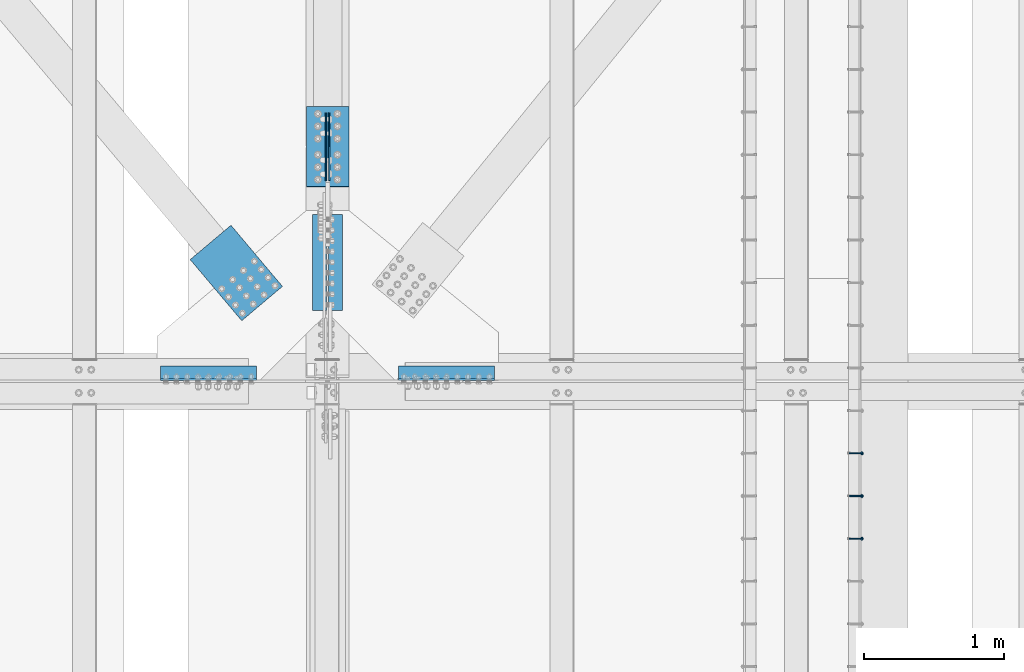
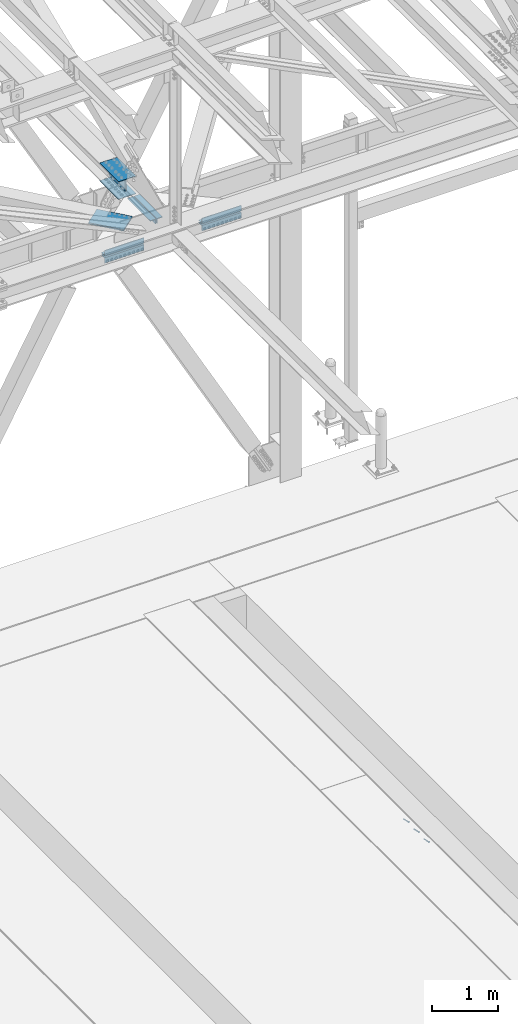
# One storey, part 2492 of 3843: 11 beams, 3 members, 5 elements without a shape of their own.
"""IFC2X3 building model written with IfcOpenShell, lengths in millimetres."""

import ifcopenshell
import ifcopenshell.guid

model = None  # the IFC model being written
_history = None  # IfcOwnerHistory: only IFC2X3 demands one
_inside = {}  # id of a spatial element -> (the spatial element, [elements in it])
_under = {}  # id of a project, library or spatial element -> (it, [spatial elements below it])
_declared = {}  # id of a project -> (the project, [libraries it declares])
_typed = {}  # id of a type object -> (the type object, [elements of that type])
_made_of = {}  # id of a material, layer set ... -> (it, [elements and type objects made of it])


def new_model(schema):
    """Start an empty IFC model of exactly this schema.

    Asked for "IFC4X3", IfcOpenShell would pick the latest addendum, in which some entities
    have other attributes; the version numbers below select the first issue.
    IFC2X3 requires an IfcOwnerHistory on every rooted entity: one is made here for all.
    """
    global model, _history
    if schema == "IFC4X3":
        model = ifcopenshell.file(schema_version=(4, 3, 0, 0))
    else:
        model = ifcopenshell.file(schema=schema)
    _inside.clear()
    _under.clear()
    _declared.clear()
    _typed.clear()
    _made_of.clear()
    _history = None
    if model.schema == "IFC2X3":
        org = make("IfcOrganization", Name="unknown")
        user = make(
            "IfcPersonAndOrganization",
            ThePerson=make("IfcPerson", FamilyName="unknown"),
            TheOrganization=org,
        )
        app = make(
            "IfcApplication",
            ApplicationDeveloper=org,
            Version="unknown",
            ApplicationFullName="unknown",
            ApplicationIdentifier="unknown",
        )
        _history = make(
            "IfcOwnerHistory",
            OwningUser=user,
            OwningApplication=app,
            ChangeAction="ADDED",
            CreationDate=0,
        )
    return model


def make(cls, **values):
    """One entity of the class cls with the attributes given. An attribute that is None is left unset."""
    return model.create_entity(
        cls, **{name: value for name, value in values.items() if value is not None}
    )


def rooted(cls, **values):
    """An entity with a GlobalId (a new one), such as an element, a storey or a relation."""
    return make(cls, GlobalId=ifcopenshell.guid.new(), OwnerHistory=_history, **values)


def si_unit(unit_type, name, prefix=None):
    """IfcSIUnit, for example si_unit("LENGTHUNIT", "METRE", prefix="MILLI")."""
    return make("IfcSIUnit", UnitType=unit_type, Prefix=prefix, Name=name)


def assignment(units):
    """IfcUnitAssignment: the units of a project."""
    return None if units is None else make("IfcUnitAssignment", Units=units)


def point(xyz):
    """IfcCartesianPoint."""
    return None if xyz is None else make("IfcCartesianPoint", Coordinates=xyz)


def direction(xyz):
    """IfcDirection."""
    return None if xyz is None else make("IfcDirection", DirectionRatios=xyz)


def frame(location, z_axis=None, x_axis=None):
    """IfcAxis2Placement3D, a coordinate frame: its origin and axes. An axis left out is left unset."""
    return make(
        "IfcAxis2Placement3D",
        Location=point(location),
        Axis=direction(z_axis),
        RefDirection=direction(x_axis),
    )


def origin_with_axes():
    """The frame at (0, 0, 0) with the z axis (0, 0, 1) and the x axis (1, 0, 0) written out."""
    return frame((0.0, 0.0, 0.0), z_axis=(0.0, 0.0, 1.0), x_axis=(1.0, 0.0, 0.0))


def place(relative_to, where):
    """IfcLocalPlacement: puts the frame where relative to a parent placement (None: the world)."""
    return make(
        "IfcLocalPlacement", PlacementRelTo=relative_to, RelativePlacement=where
    )


def context(
    kind, dimensions, precision=None, world=None, true_north=None, identifier=None
):
    """IfcGeometricRepresentationContext, for example the 3D "Model" context."""
    return make(
        "IfcGeometricRepresentationContext",
        ContextIdentifier=identifier,
        ContextType=kind,
        CoordinateSpaceDimension=dimensions,
        Precision=precision,
        WorldCoordinateSystem=world,
        TrueNorth=true_north,
    )


def subcontext(parent, identifier, kind, view, scale=None):
    """IfcGeometricRepresentationSubContext, for example "Body" below "Model"."""
    return make(
        "IfcGeometricRepresentationSubContext",
        ContextIdentifier=identifier,
        ContextType=kind,
        ParentContext=parent,
        TargetScale=scale,
        TargetView=view,
    )


def project(units=None, contexts=None):
    """IfcProject with its units and contexts."""
    return rooted(
        "IfcProject",
        Name="project",
        RepresentationContexts=contexts,
        UnitsInContext=assignment(units),
    )


def spatial(cls, under=None, at=None, **own):
    """A site, building, storey or space (cls), placed at a placement, below another one or the project."""
    s = rooted(cls, ObjectPlacement=at, **own)
    if under is not None:
        _under.setdefault(under.id(), (under, []))[1].append(s)
    return s


def faces_of(points, faces, orient=None, outer=None):
    """IfcFace entities. A face is a list of loops; a loop is a list of indices into points, from 0.

    orient and outer hold one flag for each loop. By default every Orientation is true, the
    first loop of a face is its IfcFaceOuterBound and the others are IfcFaceBound.
    """
    made = []
    for i, loops in enumerate(faces):
        bounds = []
        for j, loop in enumerate(loops):
            is_outer = j == 0 if outer is None else outer[i][j]
            bounds.append(
                make(
                    "IfcFaceOuterBound" if is_outer else "IfcFaceBound",
                    Bound=make("IfcPolyLoop", Polygon=[points[k] for k in loop]),
                    Orientation=True if orient is None else orient[i][j],
                )
            )
        made.append(make("IfcFace", Bounds=bounds))
    return made


def faceted_brep(points, faces, orient=None, outer=None, voids=None):
    """IfcFacetedBrep: a solid bounded by flat faces; with voids (closed shells), ...WithVoids."""
    shared = [point(p) for p in points]
    hull = make("IfcClosedShell", CfsFaces=faces_of(shared, faces, orient, outer))
    if voids is None:
        return make("IfcFacetedBrep", Outer=hull)
    return make(
        "IfcFacetedBrepWithVoids",
        Outer=hull,
        Voids=[
            make(cls, CfsFaces=faces_of(shared, fs, o, b)) for cls, fs, o, b in voids
        ],
    )


def shape(context_of_items, identifier, shape_type, items):
    """IfcShapeRepresentation: the items that make up one representation, for example the "Body"."""
    return make(
        "IfcShapeRepresentation",
        ContextOfItems=context_of_items,
        RepresentationIdentifier=identifier,
        RepresentationType=shape_type,
        Items=items,
    )


def material(Name=None, Category=None):
    """IfcMaterial."""
    return make("IfcMaterial", Name=Name, Category=Category)


def made_of(thing, what):
    """Note that an element or type object is made of a material, layer set ...; save() writes the relation."""
    if what is not None:
        _made_of.setdefault(what.id(), (what, []))[1].append(thing)
    return thing


def type_object(cls, material=None, **own):
    """A type object (cls), such as IfcWallType, which elements share."""
    return made_of(rooted(cls, **own), material)


def element(
    cls,
    number,
    at=None,
    inside=None,
    cuts=None,
    type_object=None,
    material=None,
    context=None,
    identifier="Body",
    shape_type=None,
    held_by="IfcProductDefinitionShape",
    body=None,
    shapes=None,
    **own,
):
    """One element of the class cls, such as IfcWall. Its Tag is "e" and its number.

    at: its placement. inside: the storey or other place that contains it. cuts: it is an
    opening in that element (IfcRelVoidsElement). A single representation is given by context,
    identifier, shape_type and body (its items); several are given by shapes. held_by: the class
    of the entity that holds the representations. save() writes the other relations.
    """
    e = rooted(cls, Tag="e%d" % number, ObjectPlacement=at, **own)
    if body is not None:
        shapes = [shape(context, identifier, shape_type, body)]
    if shapes is not None:
        e.Representation = make(held_by, Representations=shapes)
    if inside is not None:
        _inside.setdefault(inside.id(), (inside, []))[1].append(e)
    if cuts is not None:
        rooted(
            "IfcRelVoidsElement", RelatingBuildingElement=cuts, RelatedOpeningElement=e
        )
    if type_object is not None:
        _typed.setdefault(type_object.id(), (type_object, []))[1].append(e)
    return made_of(e, material)


def aggregate(whole, parts):
    """IfcRelAggregates: a whole, such as a stair, and the parts it consists of."""
    return rooted("IfcRelAggregates", RelatingObject=whole, RelatedObjects=parts)


def save(model, path):
    """Write the relations noted so far, then the file.

    IfcRelAggregates (storeys below a building ...), IfcRelContainedInSpatialStructure (elements
    in a storey), IfcRelDefinesByType, IfcRelAssociatesMaterial and IfcRelDeclares: one each for
    every whole, place, type object, material and project.
    """
    for whole, parts in _under.values():
        aggregate(whole, parts)
    for where, things in _inside.values():
        rooted(
            "IfcRelContainedInSpatialStructure",
            RelatedElements=things,
            RelatingStructure=where,
        )
    for kind, things in _typed.values():
        rooted("IfcRelDefinesByType", RelatedObjects=things, RelatingType=kind)
    for what, things in _made_of.values():
        rooted("IfcRelAssociatesMaterial", RelatedObjects=things, RelatingMaterial=what)
    for by, libraries in _declared.values():
        rooted("IfcRelDeclares", RelatingContext=by, RelatedDefinitions=libraries)
    model.write(path)


model = new_model("IFC2X3")

# Units and contexts
model_context = context("Model", 3, precision=1e-05, world=origin_with_axes())
body_context = subcontext(model_context, "Body", "Model", "MODEL_VIEW")
ifc_project = project(units=[si_unit("LENGTHUNIT", "METRE", prefix="MILLI"), si_unit("AREAUNIT", "SQUARE_METRE"), si_unit("VOLUMEUNIT", "CUBIC_METRE"), si_unit("MASSUNIT", "GRAM", prefix="KILO"), si_unit("TIMEUNIT", "SECOND"), si_unit("PLANEANGLEUNIT", "RADIAN"), si_unit("SOLIDANGLEUNIT", "STERADIAN"), si_unit("THERMODYNAMICTEMPERATUREUNIT", "DEGREE_CELSIUS"), si_unit("LUMINOUSINTENSITYUNIT", "LUMEN")], contexts=[model_context])

# Site, building, storey
site_placement = place(None, origin_with_axes())
site = spatial("IfcSite", under=ifc_project, at=site_placement, CompositionType="ELEMENT")
building_placement = place(site_placement, origin_with_axes())
building = spatial("IfcBuilding", under=site, at=building_placement, Name="Undefined", CompositionType="ELEMENT")
storey_placement = place(building_placement, origin_with_axes())
storey = spatial("IfcBuildingStorey", under=building, at=storey_placement, Name="Undefined", CompositionType="ELEMENT", Elevation=0.0)

# Assembly, members
assembly_1_placement = place(storey_placement, origin_with_axes())
assembly_1 = element("IfcElementAssembly", 1, at=assembly_1_placement, inside=storey, Name="EMBED_ANGLE", AssemblyPlace="NOTDEFINED", PredefinedType="RIGID_FRAME")
ifc_material_1 = material(Name="STEEL/A108")
member_type = type_object("IfcMemberType", PredefinedType="NOTDEFINED")
member_1_placement = place(assembly_1_placement, frame((59660.5996396484, 82861.0223186035, 30446.6625), z_axis=(0.0, 1.0, 0.0), x_axis=(0.707106781186548, 0.0, -0.707106781186548)))
member_1 = element("IfcMember", 2, at=member_1_placement, type_object=member_type, material=ifc_material_1, Name="HEADED STUD ANCHOR", context=body_context, shape_type="Brep", body=[
    faceted_brep([(7.27595761418343e-12, -3.18000006675175, 5.5), (0.0, -5.49999999998363, 3.1800000667572), (118.110000000976, -5.49999999999091, 3.1800000667572), (118.110000000983, -3.18000006675175, 5.5), (0.0, -6.3499999046162, 0.0), (118.110000000968, -6.34999990461256, 0.0), (0.0, -5.49999999998363, -3.1800000667572), (118.110000000976, -5.49999999999091, -3.1800000667572), (7.27595761418343e-12, -3.18000006675175, -5.5), (118.110000000983, -3.18000006675175, -5.5), (7.27595761418343e-12, -1.81898940354586e-12, -6.34999990463257), (118.110000000968, -1.81898940354586e-12, -6.34999990463257), (0.0, 3.18000006675175, -5.5), (118.110000000968, 3.18000006674811, -5.5), (7.27595761418343e-12, 5.49999999998363, -3.1800000667572), (118.110000000983, 5.49999999998363, -3.1800000667572), (7.27595761418343e-12, 6.3499999046162, 0.0), (118.110000000976, 6.34999990461256, 0.0), (7.27595761418343e-12, 5.49999999998363, 3.1800000667572), (118.110000000983, 5.49999999998363, 3.1800000667572), (0.0, 3.18000006675175, 5.5), (118.110000000968, 3.18000006674811, 5.5), (7.27595761418343e-12, -1.81898940354586e-12, 6.34999990463257), (118.110000000968, -1.81898940354586e-12, 6.34999990463257), (120.650000000991, -10.9899997710909, 6.34999990463257), (120.650000000998, -6.34000015257152, 10.9899997711182), (120.650000000991, -12.6999998092379, 0.0), (120.650000000991, -10.9899997710909, -6.34999990463257), (120.650000000998, -6.34000015257152, -10.9899997711182), (120.650000000991, -1.81898940354586e-12, -12.6899995803833), (120.650000000991, 6.34000015257152, -10.9899997711182), (120.650000000998, 10.9899997710909, -6.34999990463257), (120.650000000991, 12.6999998092342, 0.0), (120.650000000998, 10.9899997710909, 6.34999990463257), (120.650000000991, 6.34000015257152, 10.9899997711182), (120.650000000991, -1.81898940354586e-12, 12.6899995803833), (127.000000001048, -10.9899997710945, 6.34999990463257), (127.000000001048, -6.34000015257152, 10.9899997711182), (127.000000001048, -12.6999998092342, 0.0), (127.000000001048, -10.9899997710945, -6.34999990463257), (127.000000001048, -6.34000015257152, -10.9899997711182), (127.000000001048, 1.81898940354586e-12, -12.6899995803833), (127.000000001048, 6.34000015256788, -10.9899997711182), (127.000000001048, 10.9899997710909, -6.34999990463257), (127.000000001048, 12.6999998092379, 0.0), (127.000000001048, 10.9899997710909, 6.34999990463257), (127.000000001048, 6.34000015256788, 10.9899997711182), (127.000000001048, 1.81898940354586e-12, 12.6899995803833)], [[[0, 1, 2, 3]], [[1, 4, 5, 2]], [[4, 6, 7, 5]], [[6, 8, 9, 7]], [[8, 10, 11, 9]], [[10, 12, 13, 11]], [[12, 14, 15, 13]], [[14, 16, 17, 15]], [[16, 18, 19, 17]], [[18, 20, 21, 19]], [[20, 22, 23, 21]], [[22, 0, 3, 23]], [[22, 20, 18, 16, 14, 12, 10, 8, 6, 4, 1, 0]], [[3, 2, 24, 25]], [[2, 5, 26, 24]], [[5, 7, 27, 26]], [[7, 9, 28, 27]], [[9, 11, 29, 28]], [[11, 13, 30, 29]], [[13, 15, 31, 30]], [[15, 17, 32, 31]], [[17, 19, 33, 32]], [[19, 21, 34, 33]], [[21, 23, 35, 34]], [[23, 3, 25, 35]], [[25, 24, 36, 37]], [[24, 26, 38, 36]], [[26, 27, 39, 38]], [[27, 28, 40, 39]], [[28, 29, 41, 40]], [[29, 30, 42, 41]], [[30, 31, 43, 42]], [[31, 32, 44, 43]], [[32, 33, 45, 44]], [[33, 34, 46, 45]], [[34, 35, 47, 46]], [[35, 25, 37, 47]], [[38, 39, 40, 41, 42, 43, 44, 45, 46, 47, 37, 36]]]),
])
member_2_placement = place(assembly_1_placement, frame((59660.5996396484, 83165.8223186035, 30446.6625), z_axis=(0.0, 1.0, 0.0), x_axis=(0.707106781186548, 0.0, -0.707106781186548)))
member_2 = element("IfcMember", 3, at=member_2_placement, type_object=member_type, material=ifc_material_1, Name="HEADED STUD ANCHOR", context=body_context, shape_type="Brep", body=[
    faceted_brep([(7.27595761418343e-12, -3.18000006675175, 5.5), (0.0, -5.49999999998363, 3.1800000667572), (118.110000000976, -5.49999999999091, 3.1800000667572), (118.110000000983, -3.18000006675175, 5.5), (0.0, -6.3499999046162, 0.0), (118.110000000968, -6.34999990461256, 0.0), (0.0, -5.49999999998363, -3.1800000667572), (118.110000000976, -5.49999999999091, -3.1800000667572), (7.27595761418343e-12, -3.18000006675175, -5.5), (118.110000000983, -3.18000006675175, -5.5), (7.27595761418343e-12, -1.81898940354586e-12, -6.34999990463257), (118.110000000968, -1.81898940354586e-12, -6.34999990463257), (0.0, 3.18000006675175, -5.5), (118.110000000968, 3.18000006674811, -5.5), (7.27595761418343e-12, 5.49999999998363, -3.1800000667572), (118.110000000983, 5.49999999998363, -3.1800000667572), (7.27595761418343e-12, 6.3499999046162, 0.0), (118.110000000976, 6.34999990461256, 0.0), (7.27595761418343e-12, 5.49999999998363, 3.1800000667572), (118.110000000983, 5.49999999998363, 3.1800000667572), (0.0, 3.18000006675175, 5.5), (118.110000000968, 3.18000006674811, 5.5), (7.27595761418343e-12, -1.81898940354586e-12, 6.34999990463257), (118.110000000968, -1.81898940354586e-12, 6.34999990463257), (120.650000000991, -10.9899997710909, 6.34999990463257), (120.650000000998, -6.34000015257152, 10.9899997711182), (120.650000000991, -12.6999998092379, 0.0), (120.650000000991, -10.9899997710909, -6.34999990463257), (120.650000000998, -6.34000015257152, -10.9899997711182), (120.650000000991, -1.81898940354586e-12, -12.6899995803833), (120.650000000991, 6.34000015257152, -10.9899997711182), (120.650000000998, 10.9899997710909, -6.34999990463257), (120.650000000991, 12.6999998092342, 0.0), (120.650000000998, 10.9899997710909, 6.34999990463257), (120.650000000991, 6.34000015257152, 10.9899997711182), (120.650000000991, -1.81898940354586e-12, 12.6899995803833), (127.000000001048, -10.9899997710945, 6.34999990463257), (127.000000001048, -6.34000015257152, 10.9899997711182), (127.000000001048, -12.6999998092342, 0.0), (127.000000001048, -10.9899997710945, -6.34999990463257), (127.000000001048, -6.34000015257152, -10.9899997711182), (127.000000001048, 1.81898940354586e-12, -12.6899995803833), (127.000000001048, 6.34000015256788, -10.9899997711182), (127.000000001048, 10.9899997710909, -6.34999990463257), (127.000000001048, 12.6999998092379, 0.0), (127.000000001048, 10.9899997710909, 6.34999990463257), (127.000000001048, 6.34000015256788, 10.9899997711182), (127.000000001048, 1.81898940354586e-12, 12.6899995803833)], [[[0, 1, 2, 3]], [[1, 4, 5, 2]], [[4, 6, 7, 5]], [[6, 8, 9, 7]], [[8, 10, 11, 9]], [[10, 12, 13, 11]], [[12, 14, 15, 13]], [[14, 16, 17, 15]], [[16, 18, 19, 17]], [[18, 20, 21, 19]], [[20, 22, 23, 21]], [[22, 0, 3, 23]], [[22, 20, 18, 16, 14, 12, 10, 8, 6, 4, 1, 0]], [[3, 2, 24, 25]], [[2, 5, 26, 24]], [[5, 7, 27, 26]], [[7, 9, 28, 27]], [[9, 11, 29, 28]], [[11, 13, 30, 29]], [[13, 15, 31, 30]], [[15, 17, 32, 31]], [[17, 19, 33, 32]], [[19, 21, 34, 33]], [[21, 23, 35, 34]], [[23, 3, 25, 35]], [[25, 24, 36, 37]], [[24, 26, 38, 36]], [[26, 27, 39, 38]], [[27, 28, 40, 39]], [[28, 29, 41, 40]], [[29, 30, 42, 41]], [[30, 31, 43, 42]], [[31, 32, 44, 43]], [[32, 33, 45, 44]], [[33, 34, 46, 45]], [[34, 35, 47, 46]], [[35, 25, 37, 47]], [[38, 39, 40, 41, 42, 43, 44, 45, 46, 47, 37, 36]]]),
])
member_3_placement = place(assembly_1_placement, frame((59660.5996396484, 83470.6223186035, 30446.6625), z_axis=(0.0, 1.0, 0.0), x_axis=(0.707106781186548, 0.0, -0.707106781186548)))
member_3 = element("IfcMember", 4, at=member_3_placement, type_object=member_type, material=ifc_material_1, Name="HEADED STUD ANCHOR", context=body_context, shape_type="Brep", body=[
    faceted_brep([(7.27595761418343e-12, -3.18000006675175, 5.5), (0.0, -5.49999999998363, 3.1800000667572), (118.110000000976, -5.49999999999091, 3.1800000667572), (118.110000000983, -3.18000006675175, 5.5), (0.0, -6.3499999046162, 0.0), (118.110000000968, -6.34999990461256, 0.0), (0.0, -5.49999999998363, -3.1800000667572), (118.110000000976, -5.49999999999091, -3.1800000667572), (7.27595761418343e-12, -3.18000006675175, -5.5), (118.110000000983, -3.18000006675175, -5.5), (7.27595761418343e-12, -1.81898940354586e-12, -6.34999990463257), (118.110000000968, -1.81898940354586e-12, -6.34999990463257), (0.0, 3.18000006675175, -5.5), (118.110000000968, 3.18000006674811, -5.5), (7.27595761418343e-12, 5.49999999998363, -3.1800000667572), (118.110000000983, 5.49999999998363, -3.1800000667572), (7.27595761418343e-12, 6.3499999046162, 0.0), (118.110000000976, 6.34999990461256, 0.0), (7.27595761418343e-12, 5.49999999998363, 3.1800000667572), (118.110000000983, 5.49999999998363, 3.1800000667572), (0.0, 3.18000006675175, 5.5), (118.110000000968, 3.18000006674811, 5.5), (7.27595761418343e-12, -1.81898940354586e-12, 6.34999990463257), (118.110000000968, -1.81898940354586e-12, 6.34999990463257), (120.650000000991, -10.9899997710909, 6.34999990463257), (120.650000000998, -6.34000015257152, 10.9899997711182), (120.650000000991, -12.6999998092379, 0.0), (120.650000000991, -10.9899997710909, -6.34999990463257), (120.650000000998, -6.34000015257152, -10.9899997711182), (120.650000000991, -1.81898940354586e-12, -12.6899995803833), (120.650000000991, 6.34000015257152, -10.9899997711182), (120.650000000998, 10.9899997710909, -6.34999990463257), (120.650000000991, 12.6999998092342, 0.0), (120.650000000998, 10.9899997710909, 6.34999990463257), (120.650000000991, 6.34000015257152, 10.9899997711182), (120.650000000991, -1.81898940354586e-12, 12.6899995803833), (127.000000001048, -10.9899997710945, 6.34999990463257), (127.000000001048, -6.34000015257152, 10.9899997711182), (127.000000001048, -12.6999998092342, 0.0), (127.000000001048, -10.9899997710945, -6.34999990463257), (127.000000001048, -6.34000015257152, -10.9899997711182), (127.000000001048, 1.81898940354586e-12, -12.6899995803833), (127.000000001048, 6.34000015256788, -10.9899997711182), (127.000000001048, 10.9899997710909, -6.34999990463257), (127.000000001048, 12.6999998092379, 0.0), (127.000000001048, 10.9899997710909, 6.34999990463257), (127.000000001048, 6.34000015256788, 10.9899997711182), (127.000000001048, 1.81898940354586e-12, 12.6899995803833)], [[[0, 1, 2, 3]], [[1, 4, 5, 2]], [[4, 6, 7, 5]], [[6, 8, 9, 7]], [[8, 10, 11, 9]], [[10, 12, 13, 11]], [[12, 14, 15, 13]], [[14, 16, 17, 15]], [[16, 18, 19, 17]], [[18, 20, 21, 19]], [[20, 22, 23, 21]], [[22, 0, 3, 23]], [[22, 20, 18, 16, 14, 12, 10, 8, 6, 4, 1, 0]], [[3, 2, 24, 25]], [[2, 5, 26, 24]], [[5, 7, 27, 26]], [[7, 9, 28, 27]], [[9, 11, 29, 28]], [[11, 13, 30, 29]], [[13, 15, 31, 30]], [[15, 17, 32, 31]], [[17, 19, 33, 32]], [[19, 21, 34, 33]], [[21, 23, 35, 34]], [[23, 3, 25, 35]], [[25, 24, 36, 37]], [[24, 26, 38, 36]], [[26, 27, 39, 38]], [[27, 28, 40, 39]], [[28, 29, 41, 40]], [[29, 30, 42, 41]], [[30, 31, 43, 42]], [[31, 32, 44, 43]], [[32, 33, 45, 44]], [[33, 34, 46, 45]], [[34, 35, 47, 46]], [[35, 25, 37, 47]], [[38, 39, 40, 41, 42, 43, 44, 45, 46, 47, 37, 36]]]),
])
aggregate(assembly_1, [member_1, member_2, member_3])

# Assembly, beams
assembly_2_placement = place(storey_placement, origin_with_axes())
assembly_2 = element("IfcElementAssembly", 5, at=assembly_2_placement, inside=storey, Name="PLATE", AssemblyPlace="NOTDEFINED", PredefinedType="RIGID_FRAME")
ifc_material_2 = material(Name="STEEL/A572-50")
beam_type_1 = type_object("IfcBeamType", Name="L4X4X1/2", PredefinedType="NOTDEFINED")
beam_1_placement = place(assembly_2_placement, frame((56438.799999984, 84043.0437499978, 42297.3495005023), z_axis=(0.0, 1.0, 0.0), x_axis=(1.0, 0.0, 0.0)))
beam_1 = element("IfcBeam", 6, at=beam_1_placement, type_object=beam_type_1, material=ifc_material_2, Name="ANGLE", ObjectType="L4X4X1/2", context=body_context, shape_type="Brep", body=[
    faceted_brep([(0.0, 50.8000000000029, -50.8000000000029), (0.0, 50.8000000000029, 50.8000000000029), (685.800000000003, 50.8000000000029, 50.8000000000029), (685.800000000003, 50.8000000000029, -50.8000000000029), (0.0, 38.0999999999985, 50.8000000000029), (685.800000000003, 38.0999999999985, 50.8000000000029), (0.0, 38.0999999999985, -38.0999999999985), (685.800000000003, 38.0999999999985, -38.1000000000058), (0.0, -50.8000000000029, -38.1000000000058), (685.800000000003, -50.8000000000029, -38.1000000000058), (0.0, -50.8000000000029, -50.8000000000029), (685.800000000003, -50.8000000000029, -50.8000000000029)], [[[0, 1, 2, 3]], [[1, 4, 5, 2]], [[4, 6, 7, 5]], [[6, 8, 9, 7]], [[8, 10, 11, 9]], [[10, 0, 3, 11]], [[5, 7, 9, 11, 3, 2]], [[10, 8, 6, 4, 1, 0]]]),
])
beam_2_placement = place(assembly_2_placement, frame((57124.5999999802, 84043.0437499978, 42167.1744997194), z_axis=(0.0, 1.0, 0.0), x_axis=(-1.0, 0.0, 0.0)))
beam_2 = element("IfcBeam", 7, at=beam_2_placement, type_object=beam_type_1, material=ifc_material_2, Name="ANGLE", ObjectType="L4X4X1/2", context=body_context, shape_type="Brep", body=[
    faceted_brep([(0.0, 50.8000000000029, -50.8000000000029), (0.0, 50.8000000000029, 50.8000000000029), (685.800000000003, 50.8000000000029, 50.8000000000029), (685.800000000003, 50.8000000000029, -50.8000000000029), (0.0, 38.0999999999985, 50.8000000000029), (685.800000000003, 38.0999999999985, 50.8000000000029), (0.0, 38.0999999999985, -38.0999999999985), (685.800000000003, 38.0999999999985, -38.1000000000058), (0.0, -50.8000000000029, -38.1000000000058), (685.800000000003, -50.8000000000029, -38.1000000000058), (0.0, -50.8000000000029, -50.8000000000029), (685.800000000003, -50.8000000000029, -50.8000000000029)], [[[0, 1, 2, 3]], [[1, 4, 5, 2]], [[4, 6, 7, 5]], [[6, 8, 9, 7]], [[8, 10, 11, 9]], [[10, 0, 3, 11]], [[5, 7, 9, 11, 3, 2]], [[10, 8, 6, 4, 1, 0]]]),
])

assembly_3_placement = place(storey_placement, origin_with_axes())
assembly_3 = element("IfcElementAssembly", 8, at=assembly_3_placement, inside=storey, Name="PLATE", AssemblyPlace="NOTDEFINED", PredefinedType="RIGID_FRAME")
beam_3_placement = place(assembly_3_placement, frame((54736.9999999817, 84043.0437499542, 42297.3495004659), z_axis=(0.0, 1.0, 0.0), x_axis=(1.0, 0.0, 0.0)))
beam_3 = element("IfcBeam", 9, at=beam_3_placement, type_object=beam_type_1, material=ifc_material_2, Name="ANGLE", ObjectType="L4X4X1/2", context=body_context, shape_type="Brep", body=[
    faceted_brep([(0.0, 50.8000000000029, -50.8000000000029), (0.0, 50.8000000000029, 50.8000000000029), (685.800000000003, 50.8000000000029, 50.8000000000029), (685.800000000003, 50.8000000000029, -50.8000000000029), (0.0, 38.0999999999985, 50.8000000000029), (685.800000000003, 38.0999999999985, 50.8000000000029), (0.0, 38.0999999999985, -38.0999999999985), (685.800000000003, 38.0999999999985, -38.1000000000058), (0.0, -50.8000000000029, -38.1000000000058), (685.800000000003, -50.8000000000029, -38.1000000000058), (0.0, -50.8000000000029, -50.8000000000029), (685.800000000003, -50.8000000000029, -50.8000000000029)], [[[0, 1, 2, 3]], [[1, 4, 5, 2]], [[4, 6, 7, 5]], [[6, 8, 9, 7]], [[8, 10, 11, 9]], [[10, 0, 3, 11]], [[5, 7, 9, 11, 3, 2]], [[10, 8, 6, 4, 1, 0]]]),
])
beam_4_placement = place(assembly_3_placement, frame((55422.7999999855, 84043.0437499542, 42167.1744997229), z_axis=(0.0, 1.0, 0.0), x_axis=(-1.0, 0.0, 0.0)))
beam_4 = element("IfcBeam", 10, at=beam_4_placement, type_object=beam_type_1, material=ifc_material_2, Name="ANGLE", ObjectType="L4X4X1/2", context=body_context, shape_type="Brep", body=[
    faceted_brep([(0.0, 50.8000000000029, -50.8000000000029), (0.0, 50.8000000000029, 50.8000000000029), (685.800000000003, 50.8000000000029, 50.8000000000029), (685.800000000003, 50.8000000000029, -50.8000000000029), (0.0, 38.0999999999985, 50.8000000000029), (685.800000000003, 38.0999999999985, 50.8000000000029), (0.0, 38.0999999999985, -38.0999999999985), (685.800000000003, 38.0999999999985, -38.1000000000058), (0.0, -50.8000000000029, -38.1000000000058), (685.800000000003, -50.8000000000029, -38.1000000000058), (0.0, -50.8000000000029, -50.8000000000029), (685.800000000003, -50.8000000000029, -50.8000000000029)], [[[0, 1, 2, 3]], [[1, 4, 5, 2]], [[4, 6, 7, 5]], [[6, 8, 9, 7]], [[8, 10, 11, 9]], [[10, 0, 3, 11]], [[5, 7, 9, 11, 3, 2]], [[10, 8, 6, 4, 1, 0]]]),
])

# Beam
beam_type_2 = type_object("IfcBeamType", Name="L4X3-1/2X1/2", PredefinedType="NOTDEFINED")
beam_5_placement = place(assembly_2_placement, frame((55987.9499999819, 84493.0999999995, 42173.5249994458), z_axis=(1.0, 0.0, 0.0), x_axis=(0.0, 1.0, 0.0)))
beam_5 = element("IfcBeam", 11, at=beam_5_placement, type_object=beam_type_2, material=ifc_material_2, Name="ANGLE", ObjectType="L4X3-1/2X1/2", context=body_context, shape_type="Brep", body=[
    faceted_brep([(0.0, 44.4499999999971, -50.8000000000029), (0.0, 44.4499999999971, 50.8000000000029), (685.800000000003, 44.4499999999971, 50.8000000000029), (685.800000000003, 44.4499999999971, -50.8000000000029), (0.0, 31.75, 50.8000000000029), (685.800000000003, 31.75, 50.8000000000029), (0.0, 31.7500000838336, -38.0999999999985), (685.800000000003, 31.75, -38.0999999999985), (4.36557456851006e-11, -44.4500000000226, -38.0999999999985), (685.800000000003, -44.4499999999971, -38.0999999999985), (0.0, -44.4499999999971, -50.8000000000029), (685.800000000003, -44.4499999999971, -50.8000000000029)], [[[0, 1, 2, 3]], [[1, 4, 5, 2]], [[4, 6, 7, 5]], [[6, 8, 9, 7]], [[8, 10, 11, 9]], [[10, 0, 3, 11]], [[5, 7, 9, 11, 3, 2]], [[10, 8, 6, 4, 1, 0]]]),
])

aggregate(assembly_2, [beam_5, beam_1, beam_2])

beam_6_placement = place(assembly_3_placement, frame((55873.6499999848, 85178.9000000012, 42173.5249984924), z_axis=(-1.0, 0.0, 0.0), x_axis=(0.0, -1.0, 0.0)))
beam_6 = element("IfcBeam", 12, at=beam_6_placement, type_object=beam_type_2, material=ifc_material_2, Name="ANGLE", ObjectType="L4X3-1/2X1/2", context=body_context, shape_type="Brep", body=[
    faceted_brep([(0.0, 44.4499999999971, -50.8000000000029), (0.0, 44.4499999999971, 50.8000000000029), (685.800000000003, 44.4499999999971, 50.8000000000029), (685.800000000003, 44.4499999999971, -50.8000000000029), (0.0, 31.75, 50.8000000000029), (685.800000000003, 31.75, 50.8000000000029), (0.0, 31.7500000838336, -38.0999999999985), (685.800000000003, 31.75, -38.0999999999985), (4.36557456851006e-11, -44.4500000000226, -38.0999999999985), (685.800000000003, -44.4499999999971, -38.0999999999985), (0.0, -44.4499999999971, -50.8000000000029), (685.800000000003, -44.4499999999971, -50.8000000000029)], [[[0, 1, 2, 3]], [[1, 4, 5, 2]], [[4, 6, 7, 5]], [[6, 8, 9, 7]], [[8, 10, 11, 9]], [[10, 0, 3, 11]], [[5, 7, 9, 11, 3, 2]], [[10, 8, 6, 4, 1, 0]]]),
])

aggregate(assembly_3, [beam_6, beam_3, beam_4])

# Assembly, beams
assembly_4_placement = place(storey_placement, origin_with_axes())
assembly_4 = element("IfcElementAssembly", 13, at=assembly_4_placement, inside=storey, Name="BEAM", AssemblyPlace="NOTDEFINED", PredefinedType="RIGID_FRAME")
beam_type_3 = type_object("IfcBeamType", PredefinedType="NOTDEFINED")
beam_7_placement = place(assembly_4_placement, frame((55941.9124999914, 85420.2001555032, 42254.265216371), z_axis=(0.0, 0.00113550800035591, 0.999999355310583), x_axis=(0.0, 0.999999355310583, -0.00113550800035093)))
beam_7 = element("IfcBeam", 14, at=beam_7_placement, type_object=beam_type_3, material=ifc_material_2, Name="PLATE", context=body_context, shape_type="Brep", body=[
    faceted_brep([(-4.65661287307739e-10, 4.76249999999709, -88.9000000002779), (0.0, 4.76249999999709, 88.9000015258789), (482.600000007384, 4.76249999999709, 88.9000000010856), (482.60000000638, 4.76249999999709, -88.8999999994776), (0.0, -4.76249999999709, 88.9000015258789), (482.600000007384, -4.76249999999709, 88.9000000010856), (-4.65661287307739e-10, -4.76249999999709, -88.9000000002779), (482.60000000638, -4.76249999999709, -88.8999999994776)], [[[0, 1, 2, 3]], [[1, 4, 5, 2]], [[4, 6, 7, 5]], [[6, 0, 3, 7]], [[5, 7, 3, 2]], [[6, 4, 1, 0]]]),
])
beam_8_placement = place(assembly_4_placement, frame((55919.6874999914, 85420.2001555032, 42254.265216371), z_axis=(0.0, 0.00113550800035591, 0.999999355310583), x_axis=(0.0, 0.999999355310583, -0.00113550800035093)))
beam_8 = element("IfcBeam", 15, at=beam_8_placement, type_object=beam_type_3, material=ifc_material_2, Name="PLATE", context=body_context, shape_type="Brep", body=[
    faceted_brep([(-4.65661287307739e-10, 4.76249999999709, -88.9000000002779), (0.0, 4.76249999999709, 88.9000015258789), (482.600000007384, 4.76249999999709, 88.9000000010856), (482.60000000638, 4.76249999999709, -88.8999999994776), (0.0, -4.76249999999709, 88.9000015258789), (482.600000007384, -4.76249999999709, 88.9000000010856), (-4.65661287307739e-10, -4.76249999999709, -88.9000000002779), (482.60000000638, -4.76249999999709, -88.8999999994776)], [[[0, 1, 2, 3]], [[1, 4, 5, 2]], [[4, 6, 7, 5]], [[6, 0, 3, 7]], [[5, 7, 3, 2]], [[6, 4, 1, 0]]]),
])
beam_type_4 = type_object("IfcBeamType", PredefinedType="NOTDEFINED")
beam_9_placement = place(assembly_4_placement, frame((55930.7999999914, 85375.5663170237, 42092.3907940748), z_axis=(1.0, 0.0, 0.0), x_axis=(0.0, 0.999999355310583, -0.00113550800035093)))
beam_9 = element("IfcBeam", 16, at=beam_9_placement, type_object=beam_type_4, material=ifc_material_2, Name="PLATE", context=body_context, shape_type="Brep", body=[
    faceted_brep([(2.91038304567337e-11, 4.76250000001892, -152.400000000001), (2.91038304567337e-11, 4.76250000001892, 152.400000000001), (571.500000008222, 4.76250000096479, 152.400000000001), (571.500000008222, 4.76250000096479, -152.400000000001), (-2.91038304567337e-11, -4.76250000001164, 152.400000000001), (571.500000008164, -4.76249999906577, 152.400000000001), (-2.91038304567337e-11, -4.76250000001164, -152.400000000001), (571.500000008164, -4.76249999906577, -152.400000000001)], [[[0, 1, 2, 3]], [[1, 4, 5, 2]], [[4, 6, 7, 5]], [[6, 0, 3, 7]], [[5, 7, 3, 2]], [[6, 4, 1, 0]]]),
])
beam_10_placement = place(assembly_4_placement, frame((55930.7999999914, 85375.9340512981, 42416.2405853137), z_axis=(1.0, 0.0, 0.0), x_axis=(0.0, 0.999999355310583, -0.00113550800035093)))
beam_10 = element("IfcBeam", 17, at=beam_10_placement, type_object=beam_type_4, material=ifc_material_2, Name="PLATE", context=body_context, shape_type="Brep", body=[
    faceted_brep([(2.91038304567337e-11, 4.76250000001892, -152.400000000001), (2.91038304567337e-11, 4.76250000001892, 152.400000000001), (571.500000008222, 4.76250000096479, 152.400000000001), (571.500000008222, 4.76250000096479, -152.400000000001), (-2.91038304567337e-11, -4.76250000001164, 152.400000000001), (571.500000008164, -4.76249999906577, 152.400000000001), (-2.91038304567337e-11, -4.76250000001164, -152.400000000001), (571.500000008164, -4.76249999906577, -152.400000000001)], [[[0, 1, 2, 3]], [[1, 4, 5, 2]], [[4, 6, 7, 5]], [[6, 0, 3, 7]], [[5, 7, 3, 2]], [[6, 4, 1, 0]]]),
])
aggregate(assembly_4, [beam_7, beam_9, beam_10, beam_8])

# Assembly, beam
assembly_5_placement = place(storey_placement, origin_with_axes())
assembly_5 = element("IfcElementAssembly", 18, at=assembly_5_placement, inside=storey, AssemblyPlace="NOTDEFINED", PredefinedType="RIGID_FRAME")
beam_type_5 = type_object("IfcBeamType", PredefinedType="NOTDEFINED")
beam_11_placement = place(assembly_5_placement, frame((55462.497685503, 84540.8873587229, 42259.2494997036), z_axis=(0.764727548108142, 0.644353767091114, 0.0), x_axis=(-0.64435376709112, 0.764727548108136, 0.0)))
beam_11 = element("IfcBeam", 19, at=beam_11_placement, type_object=beam_type_5, material=ifc_material_2, Name="PLATE", context=body_context, shape_type="Brep", body=[
    faceted_brep([(5.85714587941766e-10, 12.6999999999971, -190.500000000349), (-6.14818418398499e-10, 12.6999999999971, 190.500000000364), (571.499999996191, 12.6999999999971, 190.49999999936), (571.499999997392, 12.6999999999971, -190.500000001353), (-6.14818418398499e-10, -12.6999999999971, 190.500000000364), (571.499999996191, -12.6999999999971, 190.49999999936), (5.85714587941766e-10, -12.6999999999971, -190.500000000349), (571.499999997392, -12.6999999999971, -190.500000001353)], [[[0, 1, 2, 3]], [[1, 4, 5, 2]], [[4, 6, 7, 5]], [[6, 0, 3, 7]], [[5, 7, 3, 2]], [[6, 4, 1, 0]]]),
])
aggregate(assembly_5, [beam_11])

save(model, "model.ifc")
